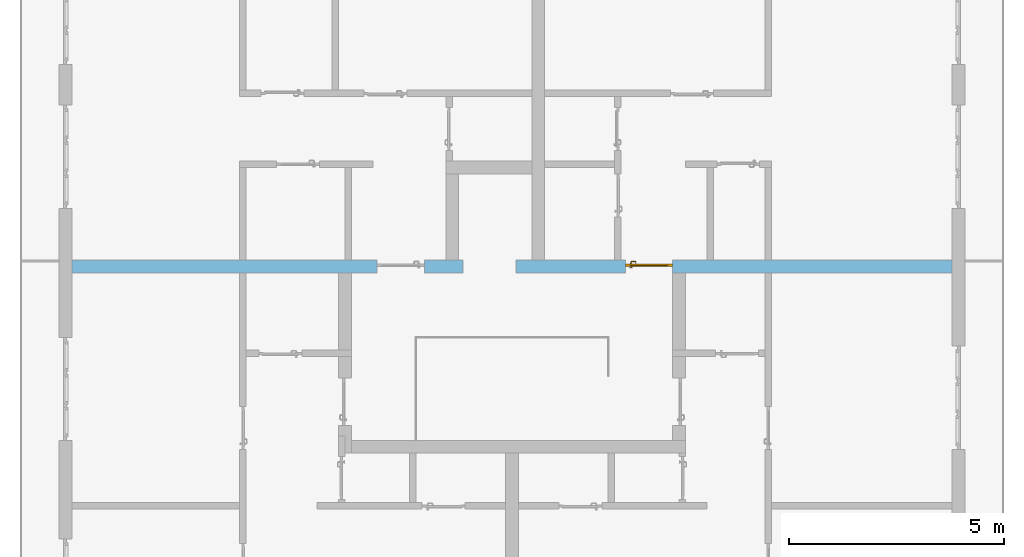
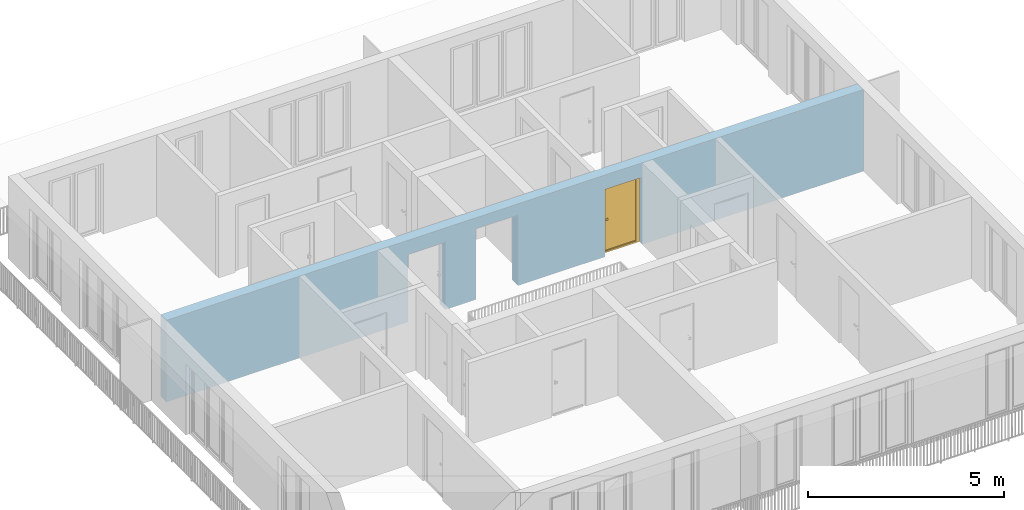
# One storey, part 17 of 54: 1 door, 3 openings, plus 1 element that does not belong to this part.
"""IFC4 building model written with IfcOpenShell, lengths in metres."""

from ifc_helpers import new_model, entity, si_unit, converted_unit, derived_unit, direction, frame, origin_with_axes, place, context, subcontext, project, spatial, polygons, source, transform, mapped, material, type_object, element, fill, save


model = new_model("IFC4")

# Units and contexts
model_context = context("Model", 3, precision=1e-05, world=origin_with_axes(), true_north=direction((0.0, 1.0)))
body_context = subcontext(model_context, "Body", "Model", "MODEL_VIEW")
ifc_project = project(units=[si_unit("LENGTHUNIT", "METRE"), si_unit("AREAUNIT", "SQUARE_METRE"), si_unit("VOLUMEUNIT", "CUBIC_METRE"), converted_unit("PLANEANGLEUNIT", "DEGREE", entity("IfcPlaneAngleMeasure", 0.0174532925199), si_unit("PLANEANGLEUNIT", "RADIAN"), dimensions=[0, 0, 0, 0, 0, 0, 0]), converted_unit("TIMEUNIT", "Year", entity("IfcTimeMeasure", 31556926.0), si_unit("TIMEUNIT", "SECOND"), dimensions=[0, 0, 1, 0, 0, 0, 0]), si_unit("MASSUNIT", "GRAM", prefix="KILO"), si_unit("THERMODYNAMICTEMPERATUREUNIT", "DEGREE_CELSIUS"), si_unit("LUMINOUSINTENSITYUNIT", "LUMEN"), si_unit("ENERGYUNIT", "JOULE", prefix="MEGA"), derived_unit("THERMALCONDUCTANCEUNIT", [(si_unit("POWERUNIT", "WATT"), 1), (si_unit("LENGTHUNIT", "METRE"), -1), (si_unit("THERMODYNAMICTEMPERATUREUNIT", "KELVIN"), -1)]), derived_unit("SPECIFICHEATCAPACITYUNIT", [(si_unit("ENERGYUNIT", "JOULE"), 1), (si_unit("MASSUNIT", "GRAM", prefix="KILO"), -1), (si_unit("THERMODYNAMICTEMPERATUREUNIT", "KELVIN"), -1)]), derived_unit("MASSDENSITYUNIT", [(si_unit("MASSUNIT", "GRAM", prefix="KILO"), 1), (si_unit("VOLUMEUNIT", "CUBIC_METRE"), -1)])], contexts=[model_context])

# Site, building, storey
site_placement = place(None, origin_with_axes())
site = spatial("IfcSite", under=ifc_project, at=site_placement, CompositionType="ELEMENT")
building_placement = place(site_placement, origin_with_axes())
building = spatial("IfcBuilding", under=site, at=building_placement, CompositionType="ELEMENT")
storey_placement = place(building_placement, frame((0.0, 0.0, 9.18), z_axis=(0.0, 0.0, 1.0), x_axis=(1.0, 0.0, 0.0)))
storey = spatial("IfcBuildingStorey", under=building, at=storey_placement, Name="3. Geschoss", CompositionType="ELEMENT", Elevation=9.18)

# Wall, openings, door
ifc_material = material()
wall_type = type_object("IfcWallType", Name="300", PredefinedType="NOTDEFINED")
wall_placement = place(storey_placement, frame((-11.7421993804, 1.37118776896, 0.0), z_axis=(0.0, 0.0, 1.0), x_axis=(1.0, 0.0, 0.0)))
wall = element("IfcWall", 1, at=wall_placement, inside=storey, type_object=wall_type, material=ifc_material, Name="Wand-001", PredefinedType="NOTDEFINED", context=body_context, shape_type="Tessellation", body=[
    polygons([(9.4, 0.3, 2.2), (9.4, 0.3, 0.0), (8.5, 0.3, 0.0), (8.5, 0.3, 2.1), (7.4, 0.3, 2.1), (7.4, 0.3, 0.0), (0.3, 0.3, 0.0), (0.3, 0.3, 2.54), (20.78, 0.3, 2.54), (20.78, 0.3, 0.0), (14.28, 0.3, 0.0), (14.28, 0.3, 2.1), (13.18, 0.3, 2.1), (13.18, 0.3, 0.0), (10.63, 0.3, 0.0), (10.63, 0.3, 2.2), (9.4, 0.0, 2.2), (9.4, 0.0, 0.0), (8.5, 0.0, 0.0), (8.5, 0.0, 2.1), (7.4, 0.0, 2.1), (7.4, 0.0, 0.0), (0.3, 0.0, 0.0), (0.3, 0.0, 2.54), (20.78, 0.0, 2.54), (20.78, 0.0, 0.0), (14.28, 0.0, 0.0), (14.28, 0.0, 2.1), (13.18, 0.0, 2.1), (13.18, 0.0, 0.0), (10.63, 0.0, 0.0), (10.63, 0.0, 2.2)], [[[1, 2, 3, 4, 5, 6, 7, 8, 9, 10, 11, 12, 13, 14, 15, 16]], [[2, 1, 17, 18]], [[2, 18, 19, 3]], [[20, 4, 3, 19]], [[21, 5, 4, 20]], [[22, 6, 5, 21]], [[7, 6, 22, 23]], [[24, 8, 7, 23]], [[25, 9, 8, 24]], [[9, 25, 26, 10]], [[10, 26, 27, 11]], [[11, 27, 28, 12]], [[12, 28, 29, 13]], [[13, 29, 30, 14]], [[31, 15, 14, 30]], [[16, 15, 31, 32]], [[1, 16, 32, 17]], [[32, 31, 30, 29, 28, 27, 26, 25, 24, 23, 22, 21, 20, 19, 18, 17]]], closed=True),
])
opening_1_placement = place(wall_placement, frame((7.95, 0.0, 0.0), z_axis=(0.0, 0.0, 1.0), x_axis=(1.0, 0.0, 0.0)))
element("IfcOpeningElement", 2, at=opening_1_placement, cuts=wall, context=body_context, identifier="Reference", shape_type="Tessellation", body=[
    polygons([(0.55, 0.15, 0.0), (0.55, 0.15, 2.1), (0.55, -0.001, 2.1), (0.55, -0.001, 0.0), (0.55, 0.301, 0.0), (0.55, 0.301, 2.1), (-0.55, 0.15, 2.1), (-0.55, -0.001, 2.1), (-0.55, 0.301, 2.1), (-0.55, -0.001, 0.0), (-0.55, 0.15, 0.0), (-0.55, 0.301, 0.0)], [[[1, 2, 3, 4]], [[2, 1, 5, 6]], [[7, 8, 3, 2, 6, 9]], [[8, 10, 4, 3]], [[1, 4, 10, 11, 12, 5]], [[6, 5, 12, 9]], [[7, 11, 10, 8]], [[11, 7, 9, 12]]], closed=True),
])
opening_2_placement = place(wall_placement, frame((13.73, 0.0, 0.0), z_axis=(0.0, 0.0, 1.0), x_axis=(1.0, 0.0, 0.0)))
opening_2 = element("IfcOpeningElement", 3, at=opening_2_placement, cuts=wall, context=body_context, identifier="Reference", shape_type="Tessellation", body=[
    polygons([(0.55, 0.15, 0.0), (0.55, 0.15, 2.1), (0.55, -0.001, 2.1), (0.55, -0.001, 0.0), (0.55, 0.301, 0.0), (0.55, 0.301, 2.1), (-0.55, 0.15, 2.1), (-0.55, -0.001, 2.1), (-0.55, 0.301, 2.1), (-0.55, -0.001, 0.0), (-0.55, 0.15, 0.0), (-0.55, 0.301, 0.0)], [[[1, 2, 3, 4]], [[2, 1, 5, 6]], [[7, 8, 3, 2, 6, 9]], [[8, 10, 4, 3]], [[1, 4, 10, 11, 12, 5]], [[6, 5, 12, 9]], [[7, 11, 10, 8]], [[11, 7, 9, 12]]], closed=True),
])
opening_3_placement = place(wall_placement, frame((10.015, 0.0, 0.0), z_axis=(0.0, 0.0, 1.0), x_axis=(1.0, 0.0, 0.0)))
element("IfcOpeningElement", 4, at=opening_3_placement, cuts=wall, context=body_context, identifier="Reference", shape_type="Tessellation", body=[
    polygons([(-0.615, -0.001, 2.2), (-0.615, -0.001, 0.0), (0.615, -0.001, 0.0), (0.615, -0.001, 2.2), (-0.615, 0.301, 2.2), (-0.615, 0.301, 0.0), (0.615, 0.301, 0.0), (0.615, 0.301, 2.2)], [[[1, 2, 3, 4]], [[5, 6, 2, 1]], [[6, 7, 3, 2]], [[7, 8, 4, 3]], [[8, 5, 1, 4]], [[7, 6, 5, 8]]], closed=True),
])
door_type = type_object("IfcDoorType", Name="Eingang 01 1-Fl 26", OperationType="SINGLE_SWING_RIGHT", PredefinedType="DOOR")
shared_shape = source(origin_with_axes(), body_context, "Body", "Tessellation", [
    polygons([(0.55, -0.05, 0.0), (0.55, -0.03, 0.0), (0.55, -0.03, 2.1), (0.55, -0.05, 2.1), (0.45, -0.05, 0.0), (0.45, -0.03, 0.0), (0.45, -0.03, 2.0), (0.1301, -0.03, 2.0), (0.0001, -0.03, 2.0), (-0.45, -0.03, 2.0), (-0.45, -0.03, 0.0), (-0.55, -0.03, 0.0), (-0.55, -0.03, 2.1), (-0.55, -0.05, 2.1), (-0.55, -0.05, 0.0), (-0.45, -0.05, 0.0), (-0.45, -0.05, 2.0), (0.0001, -0.05, 2.0), (0.1301, -0.05, 2.0), (0.45, -0.05, 2.0)], [[[1, 2, 3, 4]], [[5, 6, 2, 1]], [[2, 6, 7, 8, 9, 10, 11, 12, 13, 3]], [[4, 3, 13, 14]], [[1, 4, 14, 15, 16, 17, 18, 19, 20, 5]], [[20, 7, 6, 5]], [[19, 8, 7, 20]], [[18, 9, 8, 19]], [[17, 10, 9, 18]], [[16, 11, 10, 17]], [[15, 12, 11, 16]], [[14, 13, 12, 15]]], closed=True),
    polygons([(0.55, -0.03, 0.0), (0.55, 0.0, 0.0), (0.55, 0.0, 2.1), (0.55, -0.03, 2.1), (0.48, -0.03, 0.0), (0.48, 0.0, 0.0), (0.48, 0.0, 2.03), (0.1001, 0.0, 2.03), (0.0301, 0.0, 2.03), (-0.48, 0.0, 2.03), (-0.48, 0.0, 0.0), (-0.55, 0.0, 0.0), (-0.55, 0.0, 2.1), (-0.55, -0.03, 2.1), (-0.55, -0.03, 0.0), (-0.48, -0.03, 0.0), (-0.48, -0.03, 2.03), (0.0301, -0.03, 2.03), (0.1001, -0.03, 2.03), (0.48, -0.03, 2.03)], [[[1, 2, 3, 4]], [[5, 6, 2, 1]], [[2, 6, 7, 8, 9, 10, 11, 12, 13, 3]], [[4, 3, 13, 14]], [[1, 4, 14, 15, 16, 17, 18, 19, 20, 5]], [[20, 7, 6, 5]], [[19, 8, 7, 20]], [[18, 9, 8, 19]], [[17, 10, 9, 18]], [[16, 11, 10, 17]], [[15, 12, 11, 16]], [[14, 13, 12, 15]]], closed=True),
    polygons([(0.48, 0.01, 0.0), (-0.48, 0.01, 0.0), (-0.48, 0.01, 2.03), (0.48, 0.01, 2.03), (0.48, -0.03, 0.0), (-0.48, -0.03, 0.0), (-0.48, -0.03, 2.03), (0.48, -0.03, 2.03)], [[[1, 2, 3, 4]], [[2, 1, 5, 6]], [[3, 2, 6, 7]], [[4, 3, 7, 8]], [[1, 4, 8, 5]], [[6, 5, 8, 7]]], closed=True),
    polygons([(0.445, -0.05, 0.0), (0.445, -0.05, 0.05), (-0.445, -0.05, 0.05), (-0.445, -0.05, 0.0), (0.445, -0.03, 0.0), (0.445, -0.03, 0.07), (0.445, -0.035, 0.07), (-0.445, -0.035, 0.07), (-0.445, -0.03, 0.07), (-0.445, -0.03, 0.0)], [[[1, 2, 3, 4]], [[1, 5, 6, 7, 2]], [[2, 7, 8, 3]], [[4, 3, 8, 9, 10]], [[5, 1, 4, 10]], [[6, 5, 10, 9]], [[7, 6, 9, 8]]], closed=True),
    polygons([(-0.4335, 0.02, 1.0733826859), (-0.4335, 0.0199, 1.0733826859), (-0.42, 0.0199, 1.077), (-0.42, 0.02, 1.077), (-0.443382685902, 0.02, 1.0635), (-0.443382685902, 0.0199, 1.0635), (-0.4335, 0.0101, 1.0733826859), (-0.42, 0.0101, 1.077), (-0.4065, 0.0199, 1.0733826859), (-0.4065, 0.02, 1.0733826859), (-0.396617314098, 0.02, 1.0635), (-0.393, 0.02, 1.05), (-0.396617314098, 0.02, 1.0365), (-0.4065, 0.02, 1.0266173141), (-0.42, 0.02, 1.023), (-0.4335, 0.02, 1.0266173141), (-0.443382685902, 0.02, 1.0365), (-0.447, 0.02, 1.05), (-0.447, 0.0199, 1.05), (-0.443382685902, 0.0101, 1.0635), (-0.4335, 0.01, 1.0733826859), (-0.42, 0.01, 1.077), (-0.4065, 0.0101, 1.0733826859), (-0.396617314098, 0.0199, 1.0635), (-0.393, 0.0199, 1.05), (-0.396617314098, 0.0199, 1.0365), (-0.4065, 0.0199, 1.0266173141), (-0.42, 0.0199, 1.023), (-0.4335, 0.0199, 1.0266173141), (-0.443382685902, 0.0199, 1.0365), (-0.447, 0.0101, 1.05), (-0.443382685902, 0.01, 1.0635), (-0.447, 0.01, 1.05), (-0.443382685902, 0.01, 1.0365), (-0.4335, 0.01, 1.0266173141), (-0.42, 0.01, 1.023), (-0.4065, 0.01, 1.0266173141), (-0.396617314098, 0.01, 1.0365), (-0.393, 0.01, 1.05), (-0.396617314098, 0.01, 1.0635), (-0.4065, 0.01, 1.0733826859), (-0.396617314098, 0.0101, 1.0635), (-0.393, 0.0101, 1.05), (-0.396617314098, 0.0101, 1.0365), (-0.4065, 0.0101, 1.0266173141), (-0.42, 0.0101, 1.023), (-0.4335, 0.0101, 1.0266173141), (-0.443382685902, 0.0101, 1.0365)], [[[1, 2, 3, 4]], [[5, 6, 2, 1]], [[2, 7, 8, 3]], [[4, 3, 9, 10]], [[4, 10, 11, 12, 13, 14, 15, 16, 17, 18, 5, 1]], [[18, 19, 6, 5]], [[6, 20, 7, 2]], [[7, 21, 22, 8]], [[3, 8, 23, 9]], [[10, 9, 24, 11]], [[11, 24, 25, 12]], [[12, 25, 26, 13]], [[13, 26, 27, 14]], [[14, 27, 28, 15]], [[15, 28, 29, 16]], [[16, 29, 30, 17]], [[17, 30, 19, 18]], [[19, 31, 20, 6]], [[20, 32, 21, 7]], [[22, 21, 32, 33, 34, 35, 36, 37, 38, 39, 40, 41]], [[8, 22, 41, 23]], [[9, 23, 42, 24]], [[24, 42, 43, 25]], [[25, 43, 44, 26]], [[26, 44, 45, 27]], [[27, 45, 46, 28]], [[28, 46, 47, 29]], [[29, 47, 48, 30]], [[30, 48, 31, 19]], [[31, 33, 32, 20]], [[48, 34, 33, 31]], [[47, 35, 34, 48]], [[46, 36, 35, 47]], [[45, 37, 36, 46]], [[44, 38, 37, 45]], [[43, 39, 38, 44]], [[42, 40, 39, 43]], [[23, 41, 40, 42]]], closed=True),
    polygons([(-0.412532169224, 0.019, 0.959692280177), (-0.415, 0.019, 0.9544), (-0.415, 0.019, 0.952886751346), (-0.397569942042, 0.019, 0.96295), (-0.40705, 0.019, 0.972430057958), (-0.413279754556, 0.019, 0.961639806549), (-0.412532169224, 0.02, 0.959692280177), (-0.415, 0.02, 0.9544), (-0.415, 0.02, 0.952886751346), (-0.415, 0.02, 0.95), (-0.415, 0.02, 0.947113248654), (-0.415, 0.02, 0.941339745962), (-0.415, 0.02, 0.9375), (-0.415, 0.019, 0.9375), (-0.415, 0.019, 0.941339745962), (-0.415, 0.019, 0.947113248654), (-0.415, 0.019, 0.95), (-0.3941, 0.019, 0.95), (-0.397483339502, 0.019, 0.963), (-0.407, 0.019, 0.972516660498), (-0.414624817685, 0.019, 0.965143815798), (-0.42, 0.019, 0.9759), (-0.42, 0.019, 0.967425445323), (-0.414624817685, 0.02, 0.965143815798), (-0.413279754556, 0.02, 0.961639806549), (-0.40655, 0.02, 0.973296083362), (-0.396703916638, 0.02, 0.96345), (-0.3931, 0.02, 0.95), (-0.396703916638, 0.02, 0.93655), (-0.40655, 0.02, 0.926703916638), (-0.42, 0.02, 0.9231), (-0.42, 0.02, 0.9325), (-0.416464466094, 0.02, 0.933964466094), (-0.416464466094, 0.019, 0.933964466094), (-0.40705, 0.019, 0.927569942042), (-0.42, 0.019, 0.9325), (-0.42, 0.019, 0.9241), (-0.397569942042, 0.019, 0.93705), (-0.394, 0.019, 0.95), (-0.397483339502, 0.0189, 0.963), (-0.407, 0.0189, 0.972516660498), (-0.42, 0.019, 0.976), (-0.425375182315, 0.019, 0.965143815798), (-0.43295, 0.019, 0.972430057958), (-0.426720245444, 0.019, 0.961639806549), (-0.42, 0.02, 0.967425445323), (-0.42, 0.02, 0.9769), (-0.396617314098, 0.02, 0.9635), (-0.4065, 0.02, 0.973382685902), (-0.393, 0.02, 0.95), (-0.396617314098, 0.02, 0.9365), (-0.4065, 0.02, 0.926617314098), (-0.43345, 0.02, 0.926703916638), (-0.425, 0.02, 0.941339745962), (-0.425, 0.02, 0.9375), (-0.423535533906, 0.02, 0.933964466094), (-0.42, 0.02, 0.923), (-0.423535533906, 0.019, 0.933964466094), (-0.425, 0.019, 0.9375), (-0.425, 0.019, 0.941339745962), (-0.43295, 0.019, 0.927569942042), (-0.42, 0.019, 0.924), (-0.407, 0.019, 0.927483339502), (-0.397483339502, 0.019, 0.937), (-0.394, 0.0189, 0.95), (-0.397483339502, 0.0101, 0.963), (-0.407, 0.0101, 0.972516660498), (-0.42, 0.0189, 0.976), (-0.433, 0.019, 0.972516660498), (-0.425375182315, 0.02, 0.965143815798), (-0.427467830776, 0.019, 0.959692280177), (-0.442430057958, 0.019, 0.96295), (-0.425, 0.019, 0.952886751346), (-0.425, 0.019, 0.9544), (-0.427467830776, 0.02, 0.959692280177), (-0.426720245444, 0.02, 0.961639806549), (-0.43345, 0.02, 0.973296083362), (-0.42, 0.02, 0.977), (-0.396617314098, 0.0199, 0.9635), (-0.4065, 0.0199, 0.973382685902), (-0.393, 0.0199, 0.95), (-0.396617314098, 0.0199, 0.9365), (-0.4065, 0.0199, 0.926617314098), (-0.443296083362, 0.02, 0.93655), (-0.425, 0.02, 0.947113248654), (-0.425, 0.02, 0.9544), (-0.425, 0.019, 0.95), (-0.425, 0.019, 0.947113248654), (-0.425, 0.02, 0.95), (-0.425, 0.02, 0.952886751346), (-0.4335, 0.02, 0.926617314098), (-0.42, 0.0199, 0.923), (-0.442430057958, 0.019, 0.93705), (-0.433, 0.019, 0.927483339502), (-0.42, 0.0189, 0.924), (-0.407, 0.0189, 0.927483339502), (-0.397483339502, 0.0189, 0.937), (-0.394, 0.0101, 0.95), (-0.397483339502, 0.01, 0.963), (-0.407, 0.01, 0.972516660498), (-0.42, 0.0101, 0.976), (-0.433, 0.0189, 0.972516660498), (-0.442516660498, 0.019, 0.963), (-0.4459, 0.019, 0.95), (-0.443296083362, 0.02, 0.96345), (-0.4335, 0.02, 0.973382685902), (-0.42, 0.0199, 0.977), (-0.396617314098, 0.0101, 0.9635), (-0.4065, 0.0101, 0.973382685902), (-0.393, 0.0101, 0.95), (-0.396617314098, 0.0101, 0.9365), (-0.4065, 0.0101, 0.926617314098), (-0.443382685902, 0.02, 0.9365), (-0.4469, 0.02, 0.95), (-0.4335, 0.0199, 0.926617314098), (-0.42, 0.0101, 0.923), (-0.442516660498, 0.019, 0.937), (-0.433, 0.0189, 0.927483339502), (-0.42, 0.0101, 0.924), (-0.407, 0.0101, 0.927483339502), (-0.397483339502, 0.0101, 0.937), (-0.394, 0.01, 0.95), (-0.397396736961, 0.01, 0.96305), (-0.40695, 0.01, 0.972603263039), (-0.42, 0.01, 0.976), (-0.433, 0.0101, 0.972516660498), (-0.442516660498, 0.0189, 0.963), (-0.446, 0.019, 0.95), (-0.443382685902, 0.02, 0.9635), (-0.4335, 0.0199, 0.973382685902), (-0.42, 0.0101, 0.977), (-0.396617314098, 0.01, 0.9635), (-0.4065, 0.01, 0.973382685902), (-0.393, 0.01, 0.95), (-0.396617314098, 0.01, 0.9365), (-0.4065, 0.01, 0.926617314098), (-0.447, 0.02, 0.95), (-0.443382685902, 0.0199, 0.9365), (-0.4335, 0.0101, 0.926617314098), (-0.42, 0.01, 0.923), (-0.442516660498, 0.0189, 0.937), (-0.433, 0.0101, 0.927483339502), (-0.42, 0.01, 0.924), (-0.407, 0.01, 0.927483339502), (-0.397483339502, 0.01, 0.937), (-0.3939, 0.01, 0.95), (-0.396703916638, 0.01, 0.96345), (-0.40655, 0.01, 0.973296083362), (-0.42, 0.01, 0.9761), (-0.433, 0.01, 0.972516660498), (-0.442516660498, 0.0101, 0.963), (-0.446, 0.0189, 0.95), (-0.443382685902, 0.0199, 0.9635), (-0.4335, 0.0101, 0.973382685902), (-0.42, 0.01, 0.977), (-0.3931, 0.01, 0.95), (-0.396703916638, 0.01, 0.93655), (-0.40655, 0.01, 0.926703916638), (-0.447, 0.0199, 0.95), (-0.443382685902, 0.0101, 0.9365), (-0.4335, 0.01, 0.926617314098), (-0.42, 0.01, 0.9231), (-0.442516660498, 0.0101, 0.937), (-0.433, 0.01, 0.927483339502), (-0.42, 0.01, 0.9239), (-0.40695, 0.01, 0.927396736961), (-0.397396736961, 0.01, 0.93695), (-0.42, 0.01, 0.9769), (-0.43305, 0.01, 0.972603263039), (-0.442516660498, 0.01, 0.963), (-0.446, 0.0101, 0.95), (-0.443382685902, 0.0101, 0.9635), (-0.4335, 0.01, 0.973382685902), (-0.447, 0.0101, 0.95), (-0.443382685902, 0.01, 0.9365), (-0.43345, 0.01, 0.926703916638), (-0.442516660498, 0.01, 0.937), (-0.43305, 0.01, 0.927396736961), (-0.43345, 0.01, 0.973296083362), (-0.442603263039, 0.01, 0.96305), (-0.446, 0.01, 0.95), (-0.443382685902, 0.01, 0.9635), (-0.447, 0.01, 0.95), (-0.443296083362, 0.01, 0.93655), (-0.442603263039, 0.01, 0.93695), (-0.443296083362, 0.01, 0.96345), (-0.4461, 0.01, 0.95), (-0.4469, 0.01, 0.95)], [[[1, 2, 3, 4, 5, 6]], [[2, 1, 7, 8]], [[2, 8, 9, 10, 11, 12, 13, 14, 15, 16, 17, 3]], [[17, 18, 4, 3]], [[4, 19, 20, 5]], [[21, 6, 5, 22, 23]], [[1, 6, 21, 24, 25, 7]], [[7, 25, 26, 27, 9, 8]], [[9, 27, 28, 10]], [[10, 28, 29, 11]], [[11, 29, 30, 12]], [[31, 32, 33, 13, 12, 30]], [[14, 13, 33, 34]], [[35, 15, 14, 34, 36, 37]], [[15, 35, 38, 16]], [[16, 38, 18, 17]], [[18, 39, 19, 4]], [[19, 40, 41, 20]], [[5, 20, 42, 22]], [[43, 23, 22, 44, 45]], [[21, 23, 46, 24]], [[24, 46, 47, 26, 25]], [[48, 27, 26, 49]], [[50, 28, 27, 48]], [[51, 29, 28, 50]], [[52, 30, 29, 51]], [[53, 54, 55, 56, 32, 31]], [[34, 33, 32, 36]], [[57, 31, 30, 52]], [[37, 36, 58, 59, 60, 61]], [[37, 62, 63, 35]], [[35, 63, 64, 38]], [[38, 64, 39, 18]], [[39, 65, 40, 19]], [[40, 66, 67, 41]], [[20, 41, 68, 42]], [[22, 42, 69, 44]], [[23, 43, 70, 46]], [[71, 45, 44, 72, 73, 74]], [[43, 45, 71, 75, 76, 70]], [[70, 76, 77, 47, 46]], [[49, 26, 47, 78]], [[79, 48, 49, 80]], [[81, 50, 48, 79]], [[82, 51, 50, 81]], [[83, 52, 51, 82]], [[54, 53, 84, 85]], [[86, 74, 73, 87, 88, 60, 59, 55, 54, 85, 89, 90]], [[58, 56, 55, 59]], [[36, 32, 56, 58]], [[91, 53, 31, 57]], [[92, 57, 52, 83]], [[88, 93, 61, 60]], [[61, 94, 62, 37]], [[62, 95, 96, 63]], [[63, 96, 97, 64]], [[64, 97, 65, 39]], [[65, 98, 66, 40]], [[66, 99, 100, 67]], [[41, 67, 101, 68]], [[42, 68, 102, 69]], [[44, 69, 103, 72]], [[73, 72, 104, 87]], [[71, 74, 86, 75]], [[75, 86, 90, 105, 77, 76]], [[78, 47, 77, 106]], [[80, 49, 78, 107]], [[108, 79, 80, 109]], [[110, 81, 79, 108]], [[111, 82, 81, 110]], [[112, 83, 82, 111]], [[113, 84, 53, 91]], [[85, 84, 114, 89]], [[87, 104, 93, 88]], [[89, 114, 105, 90]], [[115, 91, 57, 92]], [[116, 92, 83, 112]], [[93, 117, 94, 61]], [[94, 118, 95, 62]], [[95, 119, 120, 96]], [[96, 120, 121, 97]], [[97, 121, 98, 65]], [[98, 122, 99, 66]], [[99, 123, 124, 100]], [[67, 100, 125, 101]], [[68, 101, 126, 102]], [[69, 102, 127, 103]], [[72, 103, 128, 104]], [[106, 77, 105, 129]], [[107, 78, 106, 130]], [[109, 80, 107, 131]], [[132, 108, 109, 133]], [[134, 110, 108, 132]], [[135, 111, 110, 134]], [[136, 112, 111, 135]], [[137, 114, 84, 113]], [[138, 113, 91, 115]], [[104, 128, 117, 93]], [[129, 105, 114, 137]], [[139, 115, 92, 116]], [[140, 116, 112, 136]], [[117, 141, 118, 94]], [[118, 142, 119, 95]], [[119, 143, 144, 120]], [[120, 144, 145, 121]], [[121, 145, 122, 98]], [[122, 146, 123, 99]], [[123, 147, 148, 124]], [[100, 124, 149, 125]], [[101, 125, 150, 126]], [[102, 126, 151, 127]], [[103, 127, 152, 128]], [[130, 106, 129, 153]], [[131, 107, 130, 154]], [[133, 109, 131, 155]], [[147, 132, 133, 148]], [[156, 134, 132, 147]], [[157, 135, 134, 156]], [[158, 136, 135, 157]], [[159, 137, 113, 138]], [[160, 138, 115, 139]], [[128, 152, 141, 117]], [[153, 129, 137, 159]], [[161, 139, 116, 140]], [[162, 140, 136, 158]], [[141, 163, 142, 118]], [[142, 164, 143, 119]], [[143, 165, 166, 144]], [[144, 166, 167, 145]], [[145, 167, 146, 122]], [[146, 156, 147, 123]], [[124, 148, 168, 149]], [[125, 149, 169, 150]], [[126, 150, 170, 151]], [[127, 151, 171, 152]], [[154, 130, 153, 172]], [[155, 131, 154, 173]], [[148, 133, 155, 168]], [[167, 157, 156, 146]], [[166, 158, 157, 167]], [[174, 159, 138, 160]], [[175, 160, 139, 161]], [[152, 171, 163, 141]], [[172, 153, 159, 174]], [[176, 161, 140, 162]], [[165, 162, 158, 166]], [[163, 177, 164, 142]], [[164, 178, 165, 143]], [[149, 168, 179, 169]], [[150, 169, 180, 170]], [[151, 170, 181, 171]], [[173, 154, 172, 182]], [[168, 155, 173, 179]], [[183, 174, 160, 175]], [[184, 175, 161, 176]], [[171, 181, 177, 163]], [[182, 172, 174, 183]], [[178, 176, 162, 165]], [[177, 185, 178, 164]], [[169, 179, 186, 180]], [[170, 180, 187, 181]], [[179, 173, 182, 186]], [[188, 183, 175, 184]], [[185, 184, 176, 178]], [[181, 187, 185, 177]], [[186, 182, 183, 188]], [[180, 186, 188, 187]], [[187, 188, 184, 185]]], closed=True),
    polygons([(-0.43, 0.02, 1.05), (-0.43, 0.0509849140336, 1.05), (-0.427071067812, 0.050696439392, 1.04292893219), (-0.427071067812, 0.02, 1.04292893219), (-0.427071067812, 0.02, 1.05707106781), (-0.427071067812, 0.050696439392, 1.05707106781), (-0.428277987014, 0.0596420579258, 1.05), (-0.425518993221, 0.0584992452783, 1.04292893219), (-0.42, 0.05, 1.04), (-0.42, 0.02, 1.04), (-0.42, 0.02, 1.06), (-0.42, 0.05, 1.06), (-0.425518993221, 0.0584992452783, 1.05707106781), (-0.422816199938, 0.0678161999379, 1.05), (-0.420704557509, 0.0657045575088, 1.04292893219), (-0.418858192988, 0.0557402514855, 1.04), (-0.412928932188, 0.049303560608, 1.04292893219), (-0.412928932188, 0.02, 1.04292893219), (-0.412928932188, 0.02, 1.05707106781), (-0.412928932188, 0.049303560608, 1.05707106781), (-0.418858192988, 0.0557402514855, 1.06), (-0.420704557509, 0.0657045575088, 1.05707106781), (-0.414642057926, 0.0732779870137, 1.05), (-0.413499245278, 0.0705189932208, 1.04292893219), (-0.415606601718, 0.0606066017178, 1.04), (-0.412197392755, 0.0529812576926, 1.04292893219), (-0.41, 0.0490150859664, 1.05), (-0.41, 0.02, 1.05), (-0.412197392755, 0.0529812576926, 1.05707106781), (-0.415606601718, 0.0606066017178, 1.06), (-0.413499245278, 0.0705189932208, 1.05707106781), (-0.405984914034, 0.075, 1.05), (-0.405696439392, 0.0720710678119, 1.04292893219), (-0.410740251485, 0.0638581929877, 1.04), (-0.410508645927, 0.0555086459268, 1.04292893219), (-0.409438398962, 0.0518384450452, 1.05), (-0.410508645927, 0.0555086459268, 1.05707106781), (-0.410740251485, 0.0638581929877, 1.06), (-0.405696439392, 0.0720710678119, 1.05707106781), (-0.324015085966, 0.075, 1.05), (-0.324303560608, 0.0720710678119, 1.04292893219), (-0.405, 0.065, 1.04), (-0.407981257693, 0.0571973927545, 1.04292893219), (-0.408397003498, 0.0533970034977, 1.05), (-0.407981257693, 0.0571973927545, 1.05707106781), (-0.405, 0.065, 1.06), (-0.324303560608, 0.0720710678119, 1.05707106781), (-0.315357942074, 0.0732779870137, 1.05), (-0.316500754722, 0.0705189932208, 1.04292893219), (-0.325, 0.065, 1.04), (-0.404303560608, 0.0579289321881, 1.04292893219), (-0.406838445045, 0.0544383989617, 1.05), (-0.404303560608, 0.0579289321881, 1.05707106781), (-0.325, 0.065, 1.06), (-0.316500754722, 0.0705189932208, 1.05707106781), (-0.307183800062, 0.0678161999379, 1.05), (-0.309295442491, 0.0657045575088, 1.04292893219), (-0.319259748515, 0.0638581929877, 1.04), (-0.325696439392, 0.0579289321881, 1.04292893219), (-0.404015085966, 0.055, 1.05), (-0.325696439392, 0.0579289321881, 1.05707106781), (-0.319259748515, 0.0638581929877, 1.06), (-0.309295442491, 0.0657045575088, 1.05707106781), (-0.301722012986, 0.0596420579258, 1.05), (-0.304481006779, 0.0584992452783, 1.04292893219), (-0.314393398282, 0.0606066017178, 1.04), (-0.322018742307, 0.0571973927545, 1.04292893219), (-0.325984914034, 0.055, 1.05), (-0.322018742307, 0.0571973927545, 1.05707106781), (-0.314393398282, 0.0606066017178, 1.06), (-0.304481006779, 0.0584992452783, 1.05707106781), (-0.3, 0.0509849140336, 1.05), (-0.302928932188, 0.050696439392, 1.04292893219), (-0.311141807012, 0.0557402514855, 1.04), (-0.319491354073, 0.0555086459268, 1.04292893219), (-0.323161554955, 0.0544383989617, 1.05), (-0.319491354073, 0.0555086459268, 1.05707106781), (-0.311141807012, 0.0557402514855, 1.06), (-0.302928932188, 0.050696439392, 1.05707106781), (-0.3, 0.02, 1.05), (-0.302928932188, 0.02, 1.04292893219), (-0.31, 0.05, 1.04), (-0.317802607245, 0.0529812576926, 1.04292893219), (-0.321602996502, 0.0533970034977, 1.05), (-0.317802607245, 0.0529812576926, 1.05707106781), (-0.31, 0.05, 1.06), (-0.302928932188, 0.02, 1.05707106781), (-0.31, 0.02, 1.06), (-0.317071067812, 0.02, 1.05707106781), (-0.32, 0.02, 1.05), (-0.317071067812, 0.02, 1.04292893219), (-0.31, 0.02, 1.04), (-0.317071067812, 0.049303560608, 1.04292893219), (-0.320561601038, 0.0518384450452, 1.05), (-0.317071067812, 0.049303560608, 1.05707106781), (-0.32, 0.0490150859664, 1.05)], [[[1, 2, 3, 4]], [[5, 6, 2, 1]], [[2, 7, 8, 3]], [[4, 3, 9, 10]], [[11, 12, 6, 5]], [[6, 13, 7, 2]], [[7, 14, 15, 8]], [[3, 8, 16, 9]], [[10, 9, 17, 18]], [[19, 20, 12, 11]], [[12, 21, 13, 6]], [[13, 22, 14, 7]], [[14, 23, 24, 15]], [[8, 15, 25, 16]], [[9, 16, 26, 17]], [[18, 17, 27, 28]], [[28, 27, 20, 19]], [[20, 29, 21, 12]], [[21, 30, 22, 13]], [[22, 31, 23, 14]], [[23, 32, 33, 24]], [[15, 24, 34, 25]], [[16, 25, 35, 26]], [[17, 26, 36, 27]], [[27, 36, 29, 20]], [[29, 37, 30, 21]], [[30, 38, 31, 22]], [[31, 39, 32, 23]], [[32, 40, 41, 33]], [[24, 33, 42, 34]], [[25, 34, 43, 35]], [[26, 35, 44, 36]], [[36, 44, 37, 29]], [[37, 45, 38, 30]], [[38, 46, 39, 31]], [[39, 47, 40, 32]], [[40, 48, 49, 41]], [[33, 41, 50, 42]], [[34, 42, 51, 43]], [[35, 43, 52, 44]], [[44, 52, 45, 37]], [[45, 53, 46, 38]], [[46, 54, 47, 39]], [[47, 55, 48, 40]], [[48, 56, 57, 49]], [[41, 49, 58, 50]], [[42, 50, 59, 51]], [[43, 51, 60, 52]], [[52, 60, 53, 45]], [[53, 61, 54, 46]], [[54, 62, 55, 47]], [[55, 63, 56, 48]], [[56, 64, 65, 57]], [[49, 57, 66, 58]], [[50, 58, 67, 59]], [[51, 59, 68, 60]], [[60, 68, 61, 53]], [[61, 69, 62, 54]], [[62, 70, 63, 55]], [[63, 71, 64, 56]], [[64, 72, 73, 65]], [[57, 65, 74, 66]], [[58, 66, 75, 67]], [[59, 67, 76, 68]], [[68, 76, 69, 61]], [[69, 77, 70, 62]], [[70, 78, 71, 63]], [[71, 79, 72, 64]], [[72, 80, 81, 73]], [[65, 73, 82, 74]], [[66, 74, 83, 75]], [[67, 75, 84, 76]], [[76, 84, 77, 69]], [[77, 85, 78, 70]], [[78, 86, 79, 71]], [[79, 87, 80, 72]], [[80, 87, 88, 89, 90, 91, 92, 81]], [[73, 81, 92, 82]], [[74, 82, 93, 83]], [[75, 83, 94, 84]], [[84, 94, 85, 77]], [[85, 95, 86, 78]], [[86, 88, 87, 79]], [[95, 89, 88, 86]], [[96, 90, 89, 95]], [[93, 91, 90, 96]], [[82, 92, 91, 93]], [[83, 93, 96, 94]], [[94, 96, 95, 85]]], closed=False),
    polygons([(-0.414696699141, -0.035, 1.04469669914), (-0.42, -0.035, 1.0425), (-0.425303300859, -0.035, 1.04469669914), (-0.4275, -0.035, 1.05), (-0.425303300859, -0.035, 1.05530330086), (-0.42, -0.035, 1.0575), (-0.414696699141, -0.035, 1.05530330086), (-0.4125, -0.035, 1.05), (-0.414696699141, -0.075, 1.04469669914), (-0.42, -0.075, 1.0425), (-0.425303300859, -0.075, 1.04469669914), (-0.4275, -0.075, 1.05), (-0.425303300859, -0.075, 1.05530330086), (-0.42, -0.075, 1.0575), (-0.414696699141, -0.075, 1.05530330086), (-0.4125, -0.075, 1.05)], [[[1, 2, 3, 4, 5, 6, 7, 8]], [[2, 1, 9, 10]], [[3, 2, 10, 11]], [[4, 3, 11, 12]], [[5, 4, 12, 13]], [[6, 5, 13, 14]], [[7, 6, 14, 15]], [[8, 7, 15, 16]], [[1, 8, 16, 9]], [[9, 16, 15, 14, 13, 12, 11, 10]]], closed=True),
    polygons([(-0.445, -0.03, 0.975), (-0.443096988313, -0.03, 0.965432914191), (-0.443096988313, -0.035, 0.965432914191), (-0.445, -0.035, 0.975), (-0.445, -0.03, 1.1), (-0.443096988313, -0.03, 1.10956708581), (-0.43767766953, -0.03, 1.11767766953), (-0.429567085809, -0.03, 1.12309698831), (-0.42, -0.03, 1.125), (-0.410432914191, -0.03, 1.12309698831), (-0.40232233047, -0.03, 1.11767766953), (-0.396903011687, -0.03, 1.10956708581), (-0.395, -0.03, 1.1), (-0.395, -0.03, 0.975), (-0.396903011687, -0.03, 0.965432914191), (-0.40232233047, -0.03, 0.95732233047), (-0.410432914191, -0.03, 0.951903011687), (-0.42, -0.03, 0.95), (-0.429567085809, -0.03, 0.951903011687), (-0.43767766953, -0.03, 0.95732233047), (-0.43767766953, -0.035, 0.95732233047), (-0.429567085809, -0.035, 0.951903011687), (-0.42, -0.035, 0.95), (-0.410432914191, -0.035, 0.951903011687), (-0.40232233047, -0.035, 0.95732233047), (-0.396903011687, -0.035, 0.965432914191), (-0.395, -0.035, 0.975), (-0.395, -0.035, 1.1), (-0.396903011687, -0.035, 1.10956708581), (-0.40232233047, -0.035, 1.11767766953), (-0.410432914191, -0.035, 1.12309698831), (-0.42, -0.035, 1.125), (-0.429567085809, -0.035, 1.12309698831), (-0.43767766953, -0.035, 1.11767766953), (-0.443096988313, -0.035, 1.10956708581), (-0.445, -0.035, 1.1)], [[[1, 2, 3, 4]], [[1, 5, 6, 7, 8, 9, 10, 11, 12, 13, 14, 15, 16, 17, 18, 19, 20, 2]], [[2, 20, 21, 3]], [[4, 3, 21, 22, 23, 24, 25, 26, 27, 28, 29, 30, 31, 32, 33, 34, 35, 36]], [[5, 1, 4, 36]], [[6, 5, 36, 35]], [[7, 6, 35, 34]], [[8, 7, 34, 33]], [[9, 8, 33, 32]], [[10, 9, 32, 31]], [[11, 10, 31, 30]], [[12, 11, 30, 29]], [[13, 12, 29, 28]], [[14, 13, 28, 27]], [[15, 14, 27, 26]], [[16, 15, 26, 25]], [[17, 16, 25, 24]], [[18, 17, 24, 23]], [[19, 18, 23, 22]], [[20, 19, 22, 21]]], closed=True),
    polygons([(-0.44, -0.075, 1.08), (-0.445, -0.075, 1.07866025404), (-0.445, -0.09, 1.07866025404), (-0.44, -0.09, 1.08), (-0.4, -0.075, 1.08), (-0.395, -0.075, 1.07866025404), (-0.391339745962, -0.075, 1.075), (-0.39, -0.075, 1.07), (-0.39, -0.075, 1.03), (-0.391339745962, -0.075, 1.025), (-0.395, -0.075, 1.02133974596), (-0.4, -0.075, 1.02), (-0.44, -0.075, 1.02), (-0.445, -0.075, 1.02133974596), (-0.448660254038, -0.075, 1.025), (-0.45, -0.075, 1.03), (-0.45, -0.075, 1.07), (-0.448660254038, -0.075, 1.075), (-0.448660254038, -0.09, 1.075), (-0.45, -0.09, 1.07), (-0.45, -0.09, 1.03), (-0.448660254038, -0.09, 1.025), (-0.445, -0.09, 1.02133974596), (-0.44, -0.09, 1.02), (-0.4, -0.09, 1.02), (-0.395, -0.09, 1.02133974596), (-0.391339745962, -0.09, 1.025), (-0.39, -0.09, 1.03), (-0.39, -0.09, 1.07), (-0.391339745962, -0.09, 1.075), (-0.395, -0.09, 1.07866025404), (-0.4, -0.09, 1.08)], [[[1, 2, 3, 4]], [[1, 5, 6, 7, 8, 9, 10, 11, 12, 13, 14, 15, 16, 17, 18, 2]], [[2, 18, 19, 3]], [[4, 3, 19, 20, 21, 22, 23, 24, 25, 26, 27, 28, 29, 30, 31, 32]], [[5, 1, 4, 32]], [[6, 5, 32, 31]], [[7, 6, 31, 30]], [[8, 7, 30, 29]], [[9, 8, 29, 28]], [[10, 9, 28, 27]], [[11, 10, 27, 26]], [[12, 11, 26, 25]], [[13, 12, 25, 24]], [[14, 13, 24, 23]], [[15, 14, 23, 22]], [[16, 15, 22, 21]], [[17, 16, 21, 20]], [[18, 17, 20, 19]]], closed=True),
])
door_placement = place(opening_2_placement, frame((-0.45, 0.0, 0.0), z_axis=(0.0, 0.0, 1.0), x_axis=(1.0, 0.0, 0.0)))
door = element("IfcDoor", 5, at=door_placement, inside=storey, type_object=door_type, OverallHeight=2.1, OverallWidth=1.1, PredefinedType="DOOR", context=body_context, shape_type="MappedRepresentation", body=[
    mapped(shared_shape, transform((0.45, 0.2, 0.0))),
])
fill(opening_2, door)

save(model, "model.ifc")
